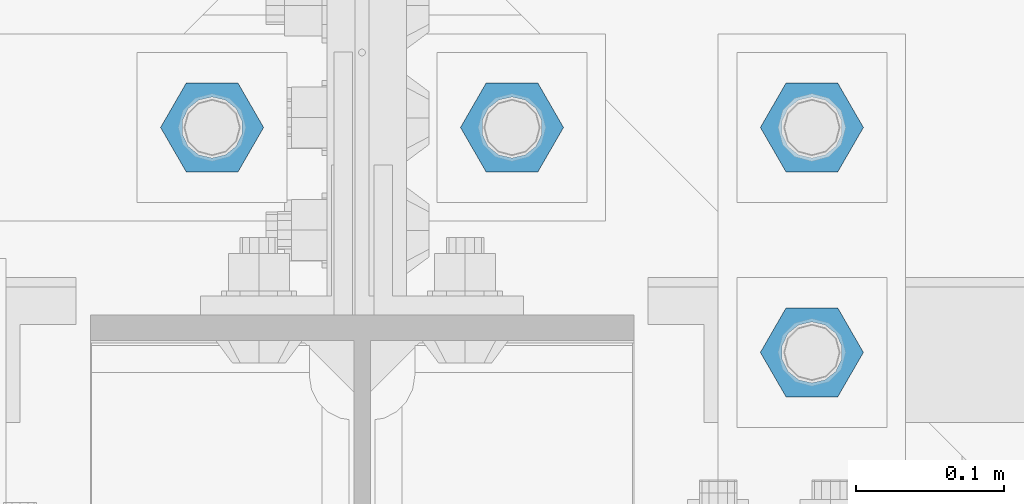
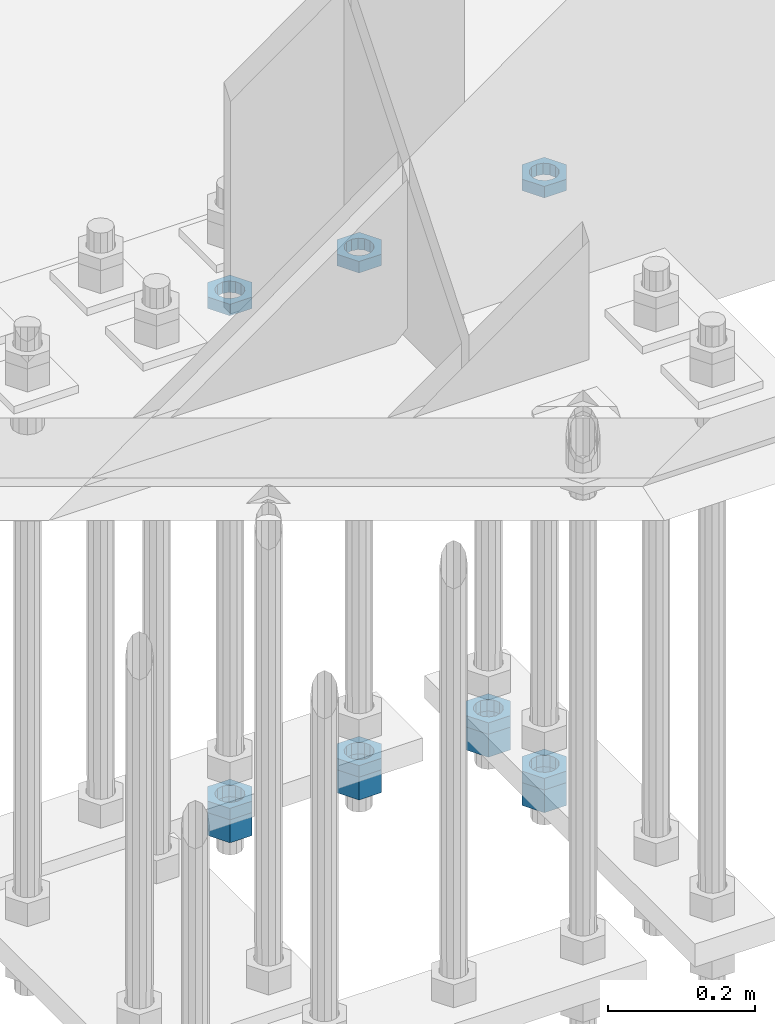
# One storey, part 2836 of 3843: 11 beams, 1 element without a shape of its own.
"""IFC2X3 building model written with IfcOpenShell, lengths in millimetres."""

from ifc_helpers import new_model, si_unit, frame, origin_with_axes, place, context, subcontext, project, spatial, faceted_brep, material, type_object, element, aggregate, save


model = new_model("IFC2X3")

# Units and contexts
model_context = context("Model", 3, precision=1e-05, world=origin_with_axes())
body_context = subcontext(model_context, "Body", "Model", "MODEL_VIEW")
ifc_project = project(units=[si_unit("LENGTHUNIT", "METRE", prefix="MILLI"), si_unit("AREAUNIT", "SQUARE_METRE"), si_unit("VOLUMEUNIT", "CUBIC_METRE"), si_unit("MASSUNIT", "GRAM", prefix="KILO"), si_unit("TIMEUNIT", "SECOND"), si_unit("PLANEANGLEUNIT", "RADIAN"), si_unit("SOLIDANGLEUNIT", "STERADIAN"), si_unit("THERMODYNAMICTEMPERATUREUNIT", "DEGREE_CELSIUS"), si_unit("LUMINOUSINTENSITYUNIT", "LUMEN")], contexts=[model_context])

# Site, building, storey
site_placement = place(None, origin_with_axes())
site = spatial("IfcSite", under=ifc_project, at=site_placement, CompositionType="ELEMENT")
building_placement = place(site_placement, origin_with_axes())
building = spatial("IfcBuilding", under=site, at=building_placement, Name="Undefined", CompositionType="ELEMENT")
storey_placement = place(building_placement, origin_with_axes())
storey = spatial("IfcBuildingStorey", under=building, at=storey_placement, Name="Undefined", CompositionType="ELEMENT", Elevation=0.0)

# Assembly, beams
assembly_placement = place(storey_placement, origin_with_axes())
assembly = element("IfcElementAssembly", 1, at=assembly_placement, inside=storey, Name="TEMPLATE", AssemblyPlace="NOTDEFINED", PredefinedType="RIGID_FRAME")
ifc_material = material(Name="STEEL/A572-50")
beam_type_1 = type_object("IfcBeamType", Name="1-1/2_HEAVY_HEX_NUT", PredefinedType="NOTDEFINED")
beam_1_placement = place(assembly_placement, frame((62941.2, 25768.3, 28746.4500015259), z_axis=(0.0, -1.0, 0.0), x_axis=(0.0, 0.0, -1.0)))
beam_1 = element("IfcBeam", 2, at=beam_1_placement, type_object=beam_type_1, material=ifc_material, Name="NUT", ObjectType="1-1/2_HEAVY_HEX_NUT", context=body_context, shape_type="Brep", body=[
    faceted_brep([(0.0, -34.9199981689453, 0.0), (0.0, -17.4599990844727, -30.25), (38.0999999999985, -17.4599990844727, -30.25), (38.0999999999985, -34.9199981689453, 0.0), (0.0, 17.4599990844727, -30.25), (38.0999999999985, 17.4599990844727, -30.25), (0.0, 34.9199981689453, 0.0), (38.0999999999985, 34.9199981689453, 0.0), (0.0, 17.4599990844727, 30.25), (38.0999999999985, 17.4599990844727, 30.25), (0.0, -17.4599990844727, 30.25), (38.0999999999985, -17.4599990844727, 30.25), (0.0, 0.0, 20.6399993896484), (0.0, 8.9553601105581, 18.5959968835959), (38.0999999999985, 8.9553601105581, 18.5959968835959), (38.0999999999985, 0.0, 20.6399993896484), (0.0, 16.1370013209525, 12.8688291298167), (38.0999999999985, 16.1370013209525, 12.8688291298167), (0.0, 20.1225115123816, 4.59283194104501), (38.0999999999985, 20.1225115123816, 4.59283194104501), (0.0, 20.1225115123816, -4.59283194104501), (38.0999999999985, 20.1225115123816, -4.59283194104501), (0.0, 16.1370013209525, -12.8688291298167), (38.0999999999985, 16.1370013209525, -12.8688291298167), (0.0, 8.9553601105581, -18.5959968835959), (38.0999999999985, 8.9553601105581, -18.5959968835959), (0.0, 0.0, -20.6399993896484), (38.0999999999985, 0.0, -20.6399993896484), (0.0, -8.9553601105581, -18.5959968835959), (38.0999999999985, -8.9553601105581, -18.5959968835959), (0.0, -16.1370013209525, -12.8688291298167), (38.0999999999985, -16.1370013209525, -12.8688291298167), (0.0, -20.1225115123816, -4.59283194104501), (38.0999999999985, -20.1225115123816, -4.59283194104501), (0.0, -20.1225115123816, 4.59283194104501), (38.0999999999985, -20.1225115123816, 4.59283194104501), (0.0, -16.1370013209525, 12.8688291298167), (38.0999999999985, -16.1370013209525, 12.8688291298167), (0.0, -8.9553601105581, 18.5959968835959), (38.0999999999985, -8.9553601105581, 18.5959968835959)], [[[0, 1, 2, 3]], [[1, 4, 5, 2]], [[4, 6, 7, 5]], [[6, 8, 9, 7]], [[8, 10, 11, 9]], [[10, 0, 3, 11]], [[12, 13, 14, 15]], [[13, 16, 17, 14]], [[16, 18, 19, 17]], [[18, 20, 21, 19]], [[20, 22, 23, 21]], [[22, 24, 25, 23]], [[24, 26, 27, 25]], [[26, 28, 29, 27]], [[28, 30, 31, 29]], [[30, 32, 33, 31]], [[32, 34, 35, 33]], [[34, 36, 37, 35]], [[36, 38, 39, 37]], [[38, 12, 15, 39]], [[5, 7, 9, 11, 3, 2], [17, 19, 21, 23, 25, 27, 29, 31, 33, 35, 37, 39, 15, 14]], [[10, 8, 6, 4, 1, 0], [38, 36, 34, 32, 30, 28, 26, 24, 22, 20, 18, 16, 13, 12]]]),
])
beam_2_placement = place(assembly_placement, frame((62941.2, 25920.7, 28746.4500015259), z_axis=(0.0, -1.0, 0.0), x_axis=(0.0, 0.0, -1.0)))
beam_2 = element("IfcBeam", 3, at=beam_2_placement, type_object=beam_type_1, material=ifc_material, Name="NUT", ObjectType="1-1/2_HEAVY_HEX_NUT", context=body_context, shape_type="Brep", body=[
    faceted_brep([(0.0, -34.9199981689453, 0.0), (0.0, -17.4599990844727, -30.25), (38.0999999999985, -17.4599990844727, -30.25), (38.0999999999985, -34.9199981689453, 0.0), (0.0, 17.4599990844727, -30.25), (38.0999999999985, 17.4599990844727, -30.25), (0.0, 34.9199981689453, 0.0), (38.0999999999985, 34.9199981689453, 0.0), (0.0, 17.4599990844727, 30.25), (38.0999999999985, 17.4599990844727, 30.25), (0.0, -17.4599990844727, 30.25), (38.0999999999985, -17.4599990844727, 30.25), (0.0, 0.0, 20.6399993896484), (0.0, 8.9553601105581, 18.5959968835959), (38.0999999999985, 8.9553601105581, 18.5959968835959), (38.0999999999985, 0.0, 20.6399993896484), (0.0, 16.1370013209525, 12.8688291298167), (38.0999999999985, 16.1370013209525, 12.8688291298167), (0.0, 20.1225115123816, 4.59283194104501), (38.0999999999985, 20.1225115123816, 4.59283194104501), (0.0, 20.1225115123816, -4.59283194104501), (38.0999999999985, 20.1225115123816, -4.59283194104501), (0.0, 16.1370013209525, -12.8688291298167), (38.0999999999985, 16.1370013209525, -12.8688291298167), (0.0, 8.9553601105581, -18.5959968835959), (38.0999999999985, 8.9553601105581, -18.5959968835959), (0.0, 0.0, -20.6399993896484), (38.0999999999985, 0.0, -20.6399993896484), (0.0, -8.9553601105581, -18.5959968835959), (38.0999999999985, -8.9553601105581, -18.5959968835959), (0.0, -16.1370013209525, -12.8688291298167), (38.0999999999985, -16.1370013209525, -12.8688291298167), (0.0, -20.1225115123816, -4.59283194104501), (38.0999999999985, -20.1225115123816, -4.59283194104501), (0.0, -20.1225115123816, 4.59283194104501), (38.0999999999985, -20.1225115123816, 4.59283194104501), (0.0, -16.1370013209525, 12.8688291298167), (38.0999999999985, -16.1370013209525, 12.8688291298167), (0.0, -8.9553601105581, 18.5959968835959), (38.0999999999985, -8.9553601105581, 18.5959968835959)], [[[0, 1, 2, 3]], [[1, 4, 5, 2]], [[4, 6, 7, 5]], [[6, 8, 9, 7]], [[8, 10, 11, 9]], [[10, 0, 3, 11]], [[12, 13, 14, 15]], [[13, 16, 17, 14]], [[16, 18, 19, 17]], [[18, 20, 21, 19]], [[20, 22, 23, 21]], [[22, 24, 25, 23]], [[24, 26, 27, 25]], [[26, 28, 29, 27]], [[28, 30, 31, 29]], [[30, 32, 33, 31]], [[32, 34, 35, 33]], [[34, 36, 37, 35]], [[36, 38, 39, 37]], [[38, 12, 15, 39]], [[5, 7, 9, 11, 3, 2], [17, 19, 21, 23, 25, 27, 29, 31, 33, 35, 37, 39, 15, 14]], [[10, 8, 6, 4, 1, 0], [38, 36, 34, 32, 30, 28, 26, 24, 22, 20, 18, 16, 13, 12]]]),
])
beam_3_placement = place(assembly_placement, frame((62738.0, 25920.7, 28746.4500015259), z_axis=(0.0, -1.0, 0.0), x_axis=(0.0, 0.0, -1.0)))
beam_3 = element("IfcBeam", 4, at=beam_3_placement, type_object=beam_type_1, material=ifc_material, Name="NUT", ObjectType="1-1/2_HEAVY_HEX_NUT", context=body_context, shape_type="Brep", body=[
    faceted_brep([(0.0, -34.9199981689453, 0.0), (0.0, -17.4599990844727, -30.25), (38.0999999999985, -17.4599990844727, -30.25), (38.0999999999985, -34.9199981689453, 0.0), (0.0, 17.4599990844727, -30.25), (38.0999999999985, 17.4599990844727, -30.25), (0.0, 34.9199981689453, 0.0), (38.0999999999985, 34.9199981689453, 0.0), (0.0, 17.4599990844727, 30.25), (38.0999999999985, 17.4599990844727, 30.25), (0.0, -17.4599990844727, 30.25), (38.0999999999985, -17.4599990844727, 30.25), (0.0, 0.0, 20.6399993896484), (0.0, 8.9553601105581, 18.5959968835959), (38.0999999999985, 8.9553601105581, 18.5959968835959), (38.0999999999985, 0.0, 20.6399993896484), (0.0, 16.1370013209525, 12.8688291298167), (38.0999999999985, 16.1370013209525, 12.8688291298167), (0.0, 20.1225115123816, 4.59283194104501), (38.0999999999985, 20.1225115123816, 4.59283194104501), (0.0, 20.1225115123816, -4.59283194104501), (38.0999999999985, 20.1225115123816, -4.59283194104501), (0.0, 16.1370013209525, -12.8688291298167), (38.0999999999985, 16.1370013209525, -12.8688291298167), (0.0, 8.9553601105581, -18.5959968835959), (38.0999999999985, 8.9553601105581, -18.5959968835959), (0.0, 0.0, -20.6399993896484), (38.0999999999985, 0.0, -20.6399993896484), (0.0, -8.9553601105581, -18.5959968835959), (38.0999999999985, -8.9553601105581, -18.5959968835959), (0.0, -16.1370013209525, -12.8688291298167), (38.0999999999985, -16.1370013209525, -12.8688291298167), (0.0, -20.1225115123816, -4.59283194104501), (38.0999999999985, -20.1225115123816, -4.59283194104501), (0.0, -20.1225115123816, 4.59283194104501), (38.0999999999985, -20.1225115123816, 4.59283194104501), (0.0, -16.1370013209525, 12.8688291298167), (38.0999999999985, -16.1370013209525, 12.8688291298167), (0.0, -8.9553601105581, 18.5959968835959), (38.0999999999985, -8.9553601105581, 18.5959968835959)], [[[0, 1, 2, 3]], [[1, 4, 5, 2]], [[4, 6, 7, 5]], [[6, 8, 9, 7]], [[8, 10, 11, 9]], [[10, 0, 3, 11]], [[12, 13, 14, 15]], [[13, 16, 17, 14]], [[16, 18, 19, 17]], [[18, 20, 21, 19]], [[20, 22, 23, 21]], [[22, 24, 25, 23]], [[24, 26, 27, 25]], [[26, 28, 29, 27]], [[28, 30, 31, 29]], [[30, 32, 33, 31]], [[32, 34, 35, 33]], [[34, 36, 37, 35]], [[36, 38, 39, 37]], [[38, 12, 15, 39]], [[5, 7, 9, 11, 3, 2], [17, 19, 21, 23, 25, 27, 29, 31, 33, 35, 37, 39, 15, 14]], [[10, 8, 6, 4, 1, 0], [38, 36, 34, 32, 30, 28, 26, 24, 22, 20, 18, 16, 13, 12]]]),
])
beam_4_placement = place(assembly_placement, frame((62534.8, 25920.7, 28746.4500015259), z_axis=(0.0, -1.0, 0.0), x_axis=(0.0, 0.0, -1.0)))
beam_4 = element("IfcBeam", 5, at=beam_4_placement, type_object=beam_type_1, material=ifc_material, Name="NUT", ObjectType="1-1/2_HEAVY_HEX_NUT", context=body_context, shape_type="Brep", body=[
    faceted_brep([(0.0, -34.9199981689453, 0.0), (0.0, -17.4599990844727, -30.25), (38.0999999999985, -17.4599990844727, -30.25), (38.0999999999985, -34.9199981689453, 0.0), (0.0, 17.4599990844727, -30.25), (38.0999999999985, 17.4599990844727, -30.25), (0.0, 34.9199981689453, 0.0), (38.0999999999985, 34.9199981689453, 0.0), (0.0, 17.4599990844727, 30.25), (38.0999999999985, 17.4599990844727, 30.25), (0.0, -17.4599990844727, 30.25), (38.0999999999985, -17.4599990844727, 30.25), (0.0, 0.0, 20.6399993896484), (0.0, 8.9553601105581, 18.5959968835959), (38.0999999999985, 8.9553601105581, 18.5959968835959), (38.0999999999985, 0.0, 20.6399993896484), (0.0, 16.1370013209525, 12.8688291298167), (38.0999999999985, 16.1370013209525, 12.8688291298167), (0.0, 20.1225115123816, 4.59283194104501), (38.0999999999985, 20.1225115123816, 4.59283194104501), (0.0, 20.1225115123816, -4.59283194104501), (38.0999999999985, 20.1225115123816, -4.59283194104501), (0.0, 16.1370013209525, -12.8688291298167), (38.0999999999985, 16.1370013209525, -12.8688291298167), (0.0, 8.9553601105581, -18.5959968835959), (38.0999999999985, 8.9553601105581, -18.5959968835959), (0.0, 0.0, -20.6399993896484), (38.0999999999985, 0.0, -20.6399993896484), (0.0, -8.9553601105581, -18.5959968835959), (38.0999999999985, -8.9553601105581, -18.5959968835959), (0.0, -16.1370013209525, -12.8688291298167), (38.0999999999985, -16.1370013209525, -12.8688291298167), (0.0, -20.1225115123816, -4.59283194104501), (38.0999999999985, -20.1225115123816, -4.59283194104501), (0.0, -20.1225115123816, 4.59283194104501), (38.0999999999985, -20.1225115123816, 4.59283194104501), (0.0, -16.1370013209525, 12.8688291298167), (38.0999999999985, -16.1370013209525, 12.8688291298167), (0.0, -8.9553601105581, 18.5959968835959), (38.0999999999985, -8.9553601105581, 18.5959968835959)], [[[0, 1, 2, 3]], [[1, 4, 5, 2]], [[4, 6, 7, 5]], [[6, 8, 9, 7]], [[8, 10, 11, 9]], [[10, 0, 3, 11]], [[12, 13, 14, 15]], [[13, 16, 17, 14]], [[16, 18, 19, 17]], [[18, 20, 21, 19]], [[20, 22, 23, 21]], [[22, 24, 25, 23]], [[24, 26, 27, 25]], [[26, 28, 29, 27]], [[28, 30, 31, 29]], [[30, 32, 33, 31]], [[32, 34, 35, 33]], [[34, 36, 37, 35]], [[36, 38, 39, 37]], [[38, 12, 15, 39]], [[5, 7, 9, 11, 3, 2], [17, 19, 21, 23, 25, 27, 29, 31, 33, 35, 37, 39, 15, 14]], [[10, 8, 6, 4, 1, 0], [38, 36, 34, 32, 30, 28, 26, 24, 22, 20, 18, 16, 13, 12]]]),
])
beam_type_2 = type_object("IfcBeamType", Name="1-1/2_HALF_NUT", PredefinedType="NOTDEFINED")
beam_5_placement = place(assembly_placement, frame((62738.0, 25920.7, 29603.7), z_axis=(0.0, 1.0, 0.0), x_axis=(0.0, 0.0, -1.0)))
beam_5 = element("IfcBeam", 6, at=beam_5_placement, type_object=beam_type_2, material=ifc_material, Name="NUT", ObjectType="1-1/2_HALF_NUT", context=body_context, shape_type="Brep", body=[
    faceted_brep([(0.0, -34.9199981689453, 0.0), (0.0, -17.4599990844727, -30.25), (19.0500000000029, -17.4599990844727, -30.25), (19.0500000000029, -34.9199981689453, 0.0), (0.0, 17.4599990844727, -30.25), (19.0500000000029, 17.4599990844727, -30.25), (0.0, 34.9199981689453, 0.0), (19.0500000000029, 34.9199981689453, 0.0), (0.0, 17.4599990844727, 30.25), (19.0500000000029, 17.4599990844727, 30.25), (0.0, -17.4599990844727, 30.25), (19.0500000000029, -17.4599990844727, 30.25), (0.0, 0.0, 20.6399993896484), (0.0, 8.9553601105581, 18.5959968835959), (19.0500000000029, 8.95536011056538, 18.5959968835959), (19.0500000000029, 0.0, 20.6399993896484), (0.0, 16.1370013209525, 12.8688291298167), (19.0500000000029, 16.1370013209489, 12.8688291298167), (0.0, 20.1225115123816, 4.59283194104501), (19.0500000000029, 20.1225115123852, 4.59283194104501), (0.0, 20.1225115123816, -4.59283194104501), (19.0500000000029, 20.1225115123852, -4.59283194104501), (0.0, 16.1370013209525, -12.8688291298167), (19.0500000000029, 16.1370013209489, -12.8688291298167), (0.0, 8.9553601105581, -18.5959968835959), (19.0500000000029, 8.95536011056538, -18.5959968835959), (0.0, 0.0, -20.6399993896484), (19.0500000000029, 0.0, -20.6399993896484), (0.0, -8.9553601105581, -18.5959968835959), (19.0500000000029, -8.95536011056538, -18.5959968835959), (0.0, -16.1370013209525, -12.8688291298167), (19.0500000000029, -16.1370013209489, -12.8688291298167), (0.0, -20.1225115123816, -4.59283194104501), (19.0500000000029, -20.1225115123852, -4.59283194104501), (0.0, -20.1225115123816, 4.59283194104501), (19.0500000000029, -20.1225115123852, 4.59283194104501), (0.0, -16.1370013209525, 12.8688291298167), (19.0500000000029, -16.1370013209489, 12.8688291298167), (0.0, -8.9553601105581, 18.5959968835959), (19.0500000000029, -8.95536011056538, 18.5959968835959)], [[[0, 1, 2, 3]], [[1, 4, 5, 2]], [[4, 6, 7, 5]], [[6, 8, 9, 7]], [[8, 10, 11, 9]], [[10, 0, 3, 11]], [[12, 13, 14, 15]], [[13, 16, 17, 14]], [[16, 18, 19, 17]], [[18, 20, 21, 19]], [[20, 22, 23, 21]], [[22, 24, 25, 23]], [[24, 26, 27, 25]], [[26, 28, 29, 27]], [[28, 30, 31, 29]], [[30, 32, 33, 31]], [[32, 34, 35, 33]], [[34, 36, 37, 35]], [[36, 38, 39, 37]], [[38, 12, 15, 39]], [[5, 7, 9, 11, 3, 2], [17, 19, 21, 23, 25, 27, 29, 31, 33, 35, 37, 39, 15, 14]], [[10, 8, 6, 4, 1, 0], [38, 36, 34, 32, 30, 28, 26, 24, 22, 20, 18, 16, 13, 12]]]),
])
beam_6_placement = place(assembly_placement, frame((62534.8, 25920.7, 29603.7), z_axis=(0.0, -1.0, 0.0), x_axis=(0.0, 0.0, -1.0)))
beam_6 = element("IfcBeam", 7, at=beam_6_placement, type_object=beam_type_2, material=ifc_material, Name="NUT", ObjectType="1-1/2_HALF_NUT", context=body_context, shape_type="Brep", body=[
    faceted_brep([(0.0, -34.9199981689453, 0.0), (0.0, -17.4599990844727, -30.25), (19.0500000000029, -17.4599990844727, -30.25), (19.0500000000029, -34.9199981689453, 0.0), (0.0, 17.4599990844727, -30.25), (19.0500000000029, 17.4599990844727, -30.25), (0.0, 34.9199981689453, 0.0), (19.0500000000029, 34.9199981689453, 0.0), (0.0, 17.4599990844727, 30.25), (19.0500000000029, 17.4599990844727, 30.25), (0.0, -17.4599990844727, 30.25), (19.0500000000029, -17.4599990844727, 30.25), (0.0, 0.0, 20.6399993896484), (0.0, 8.9553601105581, 18.5959968835959), (19.0500000000029, 8.95536011056538, 18.5959968835959), (19.0500000000029, 0.0, 20.6399993896484), (0.0, 16.1370013209525, 12.8688291298167), (19.0500000000029, 16.1370013209489, 12.8688291298167), (0.0, 20.1225115123816, 4.59283194104501), (19.0500000000029, 20.1225115123852, 4.59283194104501), (0.0, 20.1225115123816, -4.59283194104501), (19.0500000000029, 20.1225115123852, -4.59283194104501), (0.0, 16.1370013209525, -12.8688291298167), (19.0500000000029, 16.1370013209489, -12.8688291298167), (0.0, 8.9553601105581, -18.5959968835959), (19.0500000000029, 8.95536011056538, -18.5959968835959), (0.0, 0.0, -20.6399993896484), (19.0500000000029, 0.0, -20.6399993896484), (0.0, -8.9553601105581, -18.5959968835959), (19.0500000000029, -8.95536011056538, -18.5959968835959), (0.0, -16.1370013209525, -12.8688291298167), (19.0500000000029, -16.1370013209489, -12.8688291298167), (0.0, -20.1225115123816, -4.59283194104501), (19.0500000000029, -20.1225115123852, -4.59283194104501), (0.0, -20.1225115123816, 4.59283194104501), (19.0500000000029, -20.1225115123852, 4.59283194104501), (0.0, -16.1370013209525, 12.8688291298167), (19.0500000000029, -16.1370013209489, 12.8688291298167), (0.0, -8.9553601105581, 18.5959968835959), (19.0500000000029, -8.95536011056538, 18.5959968835959)], [[[0, 1, 2, 3]], [[1, 4, 5, 2]], [[4, 6, 7, 5]], [[6, 8, 9, 7]], [[8, 10, 11, 9]], [[10, 0, 3, 11]], [[12, 13, 14, 15]], [[13, 16, 17, 14]], [[16, 18, 19, 17]], [[18, 20, 21, 19]], [[20, 22, 23, 21]], [[22, 24, 25, 23]], [[24, 26, 27, 25]], [[26, 28, 29, 27]], [[28, 30, 31, 29]], [[30, 32, 33, 31]], [[32, 34, 35, 33]], [[34, 36, 37, 35]], [[36, 38, 39, 37]], [[38, 12, 15, 39]], [[5, 7, 9, 11, 3, 2], [17, 19, 21, 23, 25, 27, 29, 31, 33, 35, 37, 39, 15, 14]], [[10, 8, 6, 4, 1, 0], [38, 36, 34, 32, 30, 28, 26, 24, 22, 20, 18, 16, 13, 12]]]),
])
beam_7_placement = place(assembly_placement, frame((62941.2, 25768.3, 28765.5000015259), z_axis=(0.0, -1.0, 0.0), x_axis=(0.0, 0.0, -1.0)))
beam_7 = element("IfcBeam", 8, at=beam_7_placement, type_object=beam_type_2, material=ifc_material, Name="NUT", ObjectType="1-1/2_HALF_NUT", context=body_context, shape_type="Brep", body=[
    faceted_brep([(0.0, -34.9199981689453, 0.0), (0.0, -17.4599990844727, -30.25), (19.0500000000029, -17.4599990844727, -30.25), (19.0500000000029, -34.9199981689453, 0.0), (0.0, 17.4599990844727, -30.25), (19.0500000000029, 17.4599990844727, -30.25), (0.0, 34.9199981689453, 0.0), (19.0500000000029, 34.9199981689453, 0.0), (0.0, 17.4599990844727, 30.25), (19.0500000000029, 17.4599990844727, 30.25), (0.0, -17.4599990844727, 30.25), (19.0500000000029, -17.4599990844727, 30.25), (0.0, 0.0, 20.6399993896484), (0.0, 8.9553601105581, 18.5959968835959), (19.0500000000029, 8.95536011056538, 18.5959968835959), (19.0500000000029, 0.0, 20.6399993896484), (0.0, 16.1370013209525, 12.8688291298167), (19.0500000000029, 16.1370013209489, 12.8688291298167), (0.0, 20.1225115123816, 4.59283194104501), (19.0500000000029, 20.1225115123852, 4.59283194104501), (0.0, 20.1225115123816, -4.59283194104501), (19.0500000000029, 20.1225115123852, -4.59283194104501), (0.0, 16.1370013209525, -12.8688291298167), (19.0500000000029, 16.1370013209489, -12.8688291298167), (0.0, 8.9553601105581, -18.5959968835959), (19.0500000000029, 8.95536011056538, -18.5959968835959), (0.0, 0.0, -20.6399993896484), (19.0500000000029, 0.0, -20.6399993896484), (0.0, -8.9553601105581, -18.5959968835959), (19.0500000000029, -8.95536011056538, -18.5959968835959), (0.0, -16.1370013209525, -12.8688291298167), (19.0500000000029, -16.1370013209489, -12.8688291298167), (0.0, -20.1225115123816, -4.59283194104501), (19.0500000000029, -20.1225115123852, -4.59283194104501), (0.0, -20.1225115123816, 4.59283194104501), (19.0500000000029, -20.1225115123852, 4.59283194104501), (0.0, -16.1370013209525, 12.8688291298167), (19.0500000000029, -16.1370013209489, 12.8688291298167), (0.0, -8.9553601105581, 18.5959968835959), (19.0500000000029, -8.95536011056538, 18.5959968835959)], [[[0, 1, 2, 3]], [[1, 4, 5, 2]], [[4, 6, 7, 5]], [[6, 8, 9, 7]], [[8, 10, 11, 9]], [[10, 0, 3, 11]], [[12, 13, 14, 15]], [[13, 16, 17, 14]], [[16, 18, 19, 17]], [[18, 20, 21, 19]], [[20, 22, 23, 21]], [[22, 24, 25, 23]], [[24, 26, 27, 25]], [[26, 28, 29, 27]], [[28, 30, 31, 29]], [[30, 32, 33, 31]], [[32, 34, 35, 33]], [[34, 36, 37, 35]], [[36, 38, 39, 37]], [[38, 12, 15, 39]], [[5, 7, 9, 11, 3, 2], [17, 19, 21, 23, 25, 27, 29, 31, 33, 35, 37, 39, 15, 14]], [[10, 8, 6, 4, 1, 0], [38, 36, 34, 32, 30, 28, 26, 24, 22, 20, 18, 16, 13, 12]]]),
])
beam_8_placement = place(assembly_placement, frame((62941.2, 25920.7, 28765.5), z_axis=(0.0, -1.0, 0.0), x_axis=(0.0, 0.0, -1.0)))
beam_8 = element("IfcBeam", 9, at=beam_8_placement, type_object=beam_type_2, material=ifc_material, Name="NUT", ObjectType="1-1/2_HALF_NUT", context=body_context, shape_type="Brep", body=[
    faceted_brep([(0.0, -34.9199981689453, 0.0), (0.0, -17.4599990844727, -30.25), (19.0500000000029, -17.4599990844727, -30.25), (19.0500000000029, -34.9199981689453, 0.0), (0.0, 17.4599990844727, -30.25), (19.0500000000029, 17.4599990844727, -30.25), (0.0, 34.9199981689453, 0.0), (19.0500000000029, 34.9199981689453, 0.0), (0.0, 17.4599990844727, 30.25), (19.0500000000029, 17.4599990844727, 30.25), (0.0, -17.4599990844727, 30.25), (19.0500000000029, -17.4599990844727, 30.25), (0.0, 0.0, 20.6399993896484), (0.0, 8.9553601105581, 18.5959968835959), (19.0500000000029, 8.95536011056538, 18.5959968835959), (19.0500000000029, 0.0, 20.6399993896484), (0.0, 16.1370013209525, 12.8688291298167), (19.0500000000029, 16.1370013209489, 12.8688291298167), (0.0, 20.1225115123816, 4.59283194104501), (19.0500000000029, 20.1225115123852, 4.59283194104501), (0.0, 20.1225115123816, -4.59283194104501), (19.0500000000029, 20.1225115123852, -4.59283194104501), (0.0, 16.1370013209525, -12.8688291298167), (19.0500000000029, 16.1370013209489, -12.8688291298167), (0.0, 8.9553601105581, -18.5959968835959), (19.0500000000029, 8.95536011056538, -18.5959968835959), (0.0, 0.0, -20.6399993896484), (19.0500000000029, 0.0, -20.6399993896484), (0.0, -8.9553601105581, -18.5959968835959), (19.0500000000029, -8.95536011056538, -18.5959968835959), (0.0, -16.1370013209525, -12.8688291298167), (19.0500000000029, -16.1370013209489, -12.8688291298167), (0.0, -20.1225115123816, -4.59283194104501), (19.0500000000029, -20.1225115123852, -4.59283194104501), (0.0, -20.1225115123816, 4.59283194104501), (19.0500000000029, -20.1225115123852, 4.59283194104501), (0.0, -16.1370013209525, 12.8688291298167), (19.0500000000029, -16.1370013209489, 12.8688291298167), (0.0, -8.9553601105581, 18.5959968835959), (19.0500000000029, -8.95536011056538, 18.5959968835959)], [[[0, 1, 2, 3]], [[1, 4, 5, 2]], [[4, 6, 7, 5]], [[6, 8, 9, 7]], [[8, 10, 11, 9]], [[10, 0, 3, 11]], [[12, 13, 14, 15]], [[13, 16, 17, 14]], [[16, 18, 19, 17]], [[18, 20, 21, 19]], [[20, 22, 23, 21]], [[22, 24, 25, 23]], [[24, 26, 27, 25]], [[26, 28, 29, 27]], [[28, 30, 31, 29]], [[30, 32, 33, 31]], [[32, 34, 35, 33]], [[34, 36, 37, 35]], [[36, 38, 39, 37]], [[38, 12, 15, 39]], [[5, 7, 9, 11, 3, 2], [17, 19, 21, 23, 25, 27, 29, 31, 33, 35, 37, 39, 15, 14]], [[10, 8, 6, 4, 1, 0], [38, 36, 34, 32, 30, 28, 26, 24, 22, 20, 18, 16, 13, 12]]]),
])
beam_9_placement = place(assembly_placement, frame((62738.0, 25920.7, 28765.5000015259), z_axis=(0.0, -1.0, 0.0), x_axis=(0.0, 0.0, -1.0)))
beam_9 = element("IfcBeam", 10, at=beam_9_placement, type_object=beam_type_2, material=ifc_material, Name="NUT", ObjectType="1-1/2_HALF_NUT", context=body_context, shape_type="Brep", body=[
    faceted_brep([(0.0, -34.9199981689453, 0.0), (0.0, -17.4599990844727, -30.25), (19.0500000000029, -17.4599990844727, -30.25), (19.0500000000029, -34.9199981689453, 0.0), (0.0, 17.4599990844727, -30.25), (19.0500000000029, 17.4599990844727, -30.25), (0.0, 34.9199981689453, 0.0), (19.0500000000029, 34.9199981689453, 0.0), (0.0, 17.4599990844727, 30.25), (19.0500000000029, 17.4599990844727, 30.25), (0.0, -17.4599990844727, 30.25), (19.0500000000029, -17.4599990844727, 30.25), (0.0, 0.0, 20.6399993896484), (0.0, 8.9553601105581, 18.5959968835959), (19.0500000000029, 8.95536011056538, 18.5959968835959), (19.0500000000029, 0.0, 20.6399993896484), (0.0, 16.1370013209525, 12.8688291298167), (19.0500000000029, 16.1370013209489, 12.8688291298167), (0.0, 20.1225115123816, 4.59283194104501), (19.0500000000029, 20.1225115123852, 4.59283194104501), (0.0, 20.1225115123816, -4.59283194104501), (19.0500000000029, 20.1225115123852, -4.59283194104501), (0.0, 16.1370013209525, -12.8688291298167), (19.0500000000029, 16.1370013209489, -12.8688291298167), (0.0, 8.9553601105581, -18.5959968835959), (19.0500000000029, 8.95536011056538, -18.5959968835959), (0.0, 0.0, -20.6399993896484), (19.0500000000029, 0.0, -20.6399993896484), (0.0, -8.9553601105581, -18.5959968835959), (19.0500000000029, -8.95536011056538, -18.5959968835959), (0.0, -16.1370013209525, -12.8688291298167), (19.0500000000029, -16.1370013209489, -12.8688291298167), (0.0, -20.1225115123816, -4.59283194104501), (19.0500000000029, -20.1225115123852, -4.59283194104501), (0.0, -20.1225115123816, 4.59283194104501), (19.0500000000029, -20.1225115123852, 4.59283194104501), (0.0, -16.1370013209525, 12.8688291298167), (19.0500000000029, -16.1370013209489, 12.8688291298167), (0.0, -8.9553601105581, 18.5959968835959), (19.0500000000029, -8.95536011056538, 18.5959968835959)], [[[0, 1, 2, 3]], [[1, 4, 5, 2]], [[4, 6, 7, 5]], [[6, 8, 9, 7]], [[8, 10, 11, 9]], [[10, 0, 3, 11]], [[12, 13, 14, 15]], [[13, 16, 17, 14]], [[16, 18, 19, 17]], [[18, 20, 21, 19]], [[20, 22, 23, 21]], [[22, 24, 25, 23]], [[24, 26, 27, 25]], [[26, 28, 29, 27]], [[28, 30, 31, 29]], [[30, 32, 33, 31]], [[32, 34, 35, 33]], [[34, 36, 37, 35]], [[36, 38, 39, 37]], [[38, 12, 15, 39]], [[5, 7, 9, 11, 3, 2], [17, 19, 21, 23, 25, 27, 29, 31, 33, 35, 37, 39, 15, 14]], [[10, 8, 6, 4, 1, 0], [38, 36, 34, 32, 30, 28, 26, 24, 22, 20, 18, 16, 13, 12]]]),
])
beam_10_placement = place(assembly_placement, frame((62534.8, 25920.7, 28765.5000015259), z_axis=(0.0, -1.0, 0.0), x_axis=(0.0, 0.0, -1.0)))
beam_10 = element("IfcBeam", 11, at=beam_10_placement, type_object=beam_type_2, material=ifc_material, Name="NUT", ObjectType="1-1/2_HALF_NUT", context=body_context, shape_type="Brep", body=[
    faceted_brep([(0.0, -34.9199981689453, 0.0), (0.0, -17.4599990844727, -30.25), (19.0500000000029, -17.4599990844727, -30.25), (19.0500000000029, -34.9199981689453, 0.0), (0.0, 17.4599990844727, -30.25), (19.0500000000029, 17.4599990844727, -30.25), (0.0, 34.9199981689453, 0.0), (19.0500000000029, 34.9199981689453, 0.0), (0.0, 17.4599990844727, 30.25), (19.0500000000029, 17.4599990844727, 30.25), (0.0, -17.4599990844727, 30.25), (19.0500000000029, -17.4599990844727, 30.25), (0.0, 0.0, 20.6399993896484), (0.0, 8.9553601105581, 18.5959968835959), (19.0500000000029, 8.95536011056538, 18.5959968835959), (19.0500000000029, 0.0, 20.6399993896484), (0.0, 16.1370013209525, 12.8688291298167), (19.0500000000029, 16.1370013209489, 12.8688291298167), (0.0, 20.1225115123816, 4.59283194104501), (19.0500000000029, 20.1225115123852, 4.59283194104501), (0.0, 20.1225115123816, -4.59283194104501), (19.0500000000029, 20.1225115123852, -4.59283194104501), (0.0, 16.1370013209525, -12.8688291298167), (19.0500000000029, 16.1370013209489, -12.8688291298167), (0.0, 8.9553601105581, -18.5959968835959), (19.0500000000029, 8.95536011056538, -18.5959968835959), (0.0, 0.0, -20.6399993896484), (19.0500000000029, 0.0, -20.6399993896484), (0.0, -8.9553601105581, -18.5959968835959), (19.0500000000029, -8.95536011056538, -18.5959968835959), (0.0, -16.1370013209525, -12.8688291298167), (19.0500000000029, -16.1370013209489, -12.8688291298167), (0.0, -20.1225115123816, -4.59283194104501), (19.0500000000029, -20.1225115123852, -4.59283194104501), (0.0, -20.1225115123816, 4.59283194104501), (19.0500000000029, -20.1225115123852, 4.59283194104501), (0.0, -16.1370013209525, 12.8688291298167), (19.0500000000029, -16.1370013209489, 12.8688291298167), (0.0, -8.9553601105581, 18.5959968835959), (19.0500000000029, -8.95536011056538, 18.5959968835959)], [[[0, 1, 2, 3]], [[1, 4, 5, 2]], [[4, 6, 7, 5]], [[6, 8, 9, 7]], [[8, 10, 11, 9]], [[10, 0, 3, 11]], [[12, 13, 14, 15]], [[13, 16, 17, 14]], [[16, 18, 19, 17]], [[18, 20, 21, 19]], [[20, 22, 23, 21]], [[22, 24, 25, 23]], [[24, 26, 27, 25]], [[26, 28, 29, 27]], [[28, 30, 31, 29]], [[30, 32, 33, 31]], [[32, 34, 35, 33]], [[34, 36, 37, 35]], [[36, 38, 39, 37]], [[38, 12, 15, 39]], [[5, 7, 9, 11, 3, 2], [17, 19, 21, 23, 25, 27, 29, 31, 33, 35, 37, 39, 15, 14]], [[10, 8, 6, 4, 1, 0], [38, 36, 34, 32, 30, 28, 26, 24, 22, 20, 18, 16, 13, 12]]]),
])
beam_11_placement = place(assembly_placement, frame((62941.2, 25768.3, 29749.75), z_axis=(0.0, -1.0, 0.0), x_axis=(0.0, 0.0, -1.0)))
beam_11 = element("IfcBeam", 12, at=beam_11_placement, type_object=beam_type_2, material=ifc_material, Name="NUT", ObjectType="1-1/2_HALF_NUT", context=body_context, shape_type="Brep", body=[
    faceted_brep([(0.0, -34.9199981689453, 0.0), (0.0, -17.4599990844727, -30.25), (19.0500000000029, -17.4599990844727, -30.25), (19.0500000000029, -34.9199981689453, 0.0), (0.0, 17.4599990844727, -30.25), (19.0500000000029, 17.4599990844727, -30.25), (0.0, 34.9199981689453, 0.0), (19.0500000000029, 34.9199981689453, 0.0), (0.0, 17.4599990844727, 30.25), (19.0500000000029, 17.4599990844727, 30.25), (0.0, -17.4599990844727, 30.25), (19.0500000000029, -17.4599990844727, 30.25), (0.0, 0.0, 20.6399993896484), (0.0, 8.9553601105581, 18.5959968835959), (19.0500000000029, 8.95536011056538, 18.5959968835959), (19.0500000000029, 0.0, 20.6399993896484), (0.0, 16.1370013209525, 12.8688291298167), (19.0500000000029, 16.1370013209489, 12.8688291298167), (0.0, 20.1225115123816, 4.59283194104501), (19.0500000000029, 20.1225115123852, 4.59283194104501), (0.0, 20.1225115123816, -4.59283194104501), (19.0500000000029, 20.1225115123852, -4.59283194104501), (0.0, 16.1370013209525, -12.8688291298167), (19.0500000000029, 16.1370013209489, -12.8688291298167), (0.0, 8.9553601105581, -18.5959968835959), (19.0500000000029, 8.95536011056538, -18.5959968835959), (0.0, 0.0, -20.6399993896484), (19.0500000000029, 0.0, -20.6399993896484), (0.0, -8.9553601105581, -18.5959968835959), (19.0500000000029, -8.95536011056538, -18.5959968835959), (0.0, -16.1370013209525, -12.8688291298167), (19.0500000000029, -16.1370013209489, -12.8688291298167), (0.0, -20.1225115123816, -4.59283194104501), (19.0500000000029, -20.1225115123852, -4.59283194104501), (0.0, -20.1225115123816, 4.59283194104501), (19.0500000000029, -20.1225115123852, 4.59283194104501), (0.0, -16.1370013209525, 12.8688291298167), (19.0500000000029, -16.1370013209489, 12.8688291298167), (0.0, -8.9553601105581, 18.5959968835959), (19.0500000000029, -8.95536011056538, 18.5959968835959)], [[[0, 1, 2, 3]], [[1, 4, 5, 2]], [[4, 6, 7, 5]], [[6, 8, 9, 7]], [[8, 10, 11, 9]], [[10, 0, 3, 11]], [[12, 13, 14, 15]], [[13, 16, 17, 14]], [[16, 18, 19, 17]], [[18, 20, 21, 19]], [[20, 22, 23, 21]], [[22, 24, 25, 23]], [[24, 26, 27, 25]], [[26, 28, 29, 27]], [[28, 30, 31, 29]], [[30, 32, 33, 31]], [[32, 34, 35, 33]], [[34, 36, 37, 35]], [[36, 38, 39, 37]], [[38, 12, 15, 39]], [[5, 7, 9, 11, 3, 2], [17, 19, 21, 23, 25, 27, 29, 31, 33, 35, 37, 39, 15, 14]], [[10, 8, 6, 4, 1, 0], [38, 36, 34, 32, 30, 28, 26, 24, 22, 20, 18, 16, 13, 12]]]),
])
aggregate(assembly, [beam_5, beam_6, beam_7, beam_8, beam_9, beam_10, beam_1, beam_2, beam_3, beam_4, beam_11])

save(model, "model.ifc")
